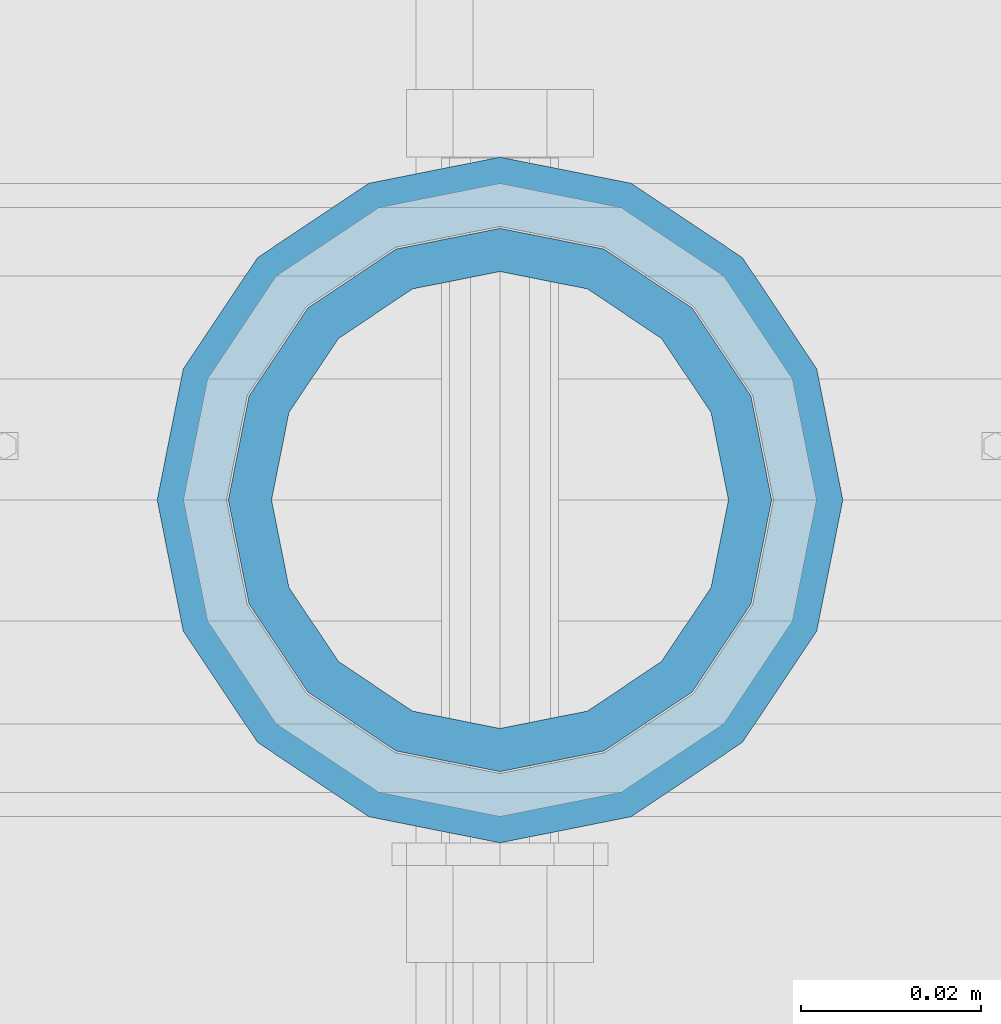
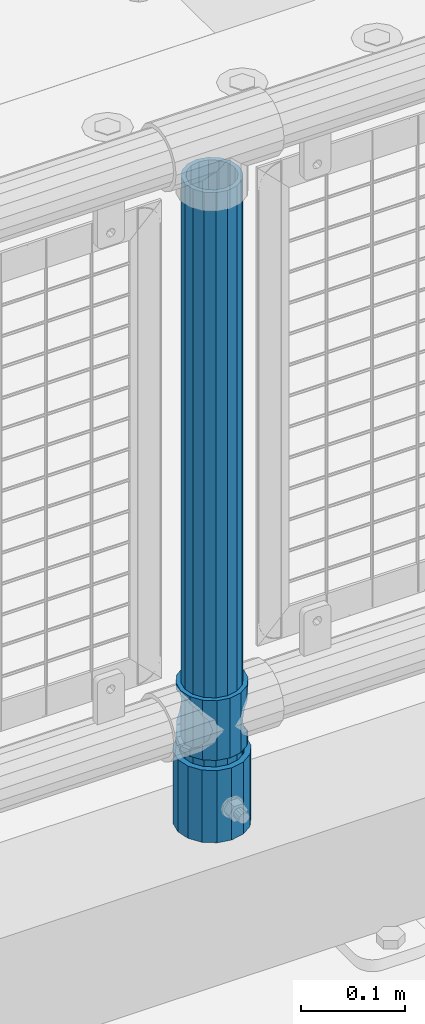
# One storey, part 81 of 270: 3 columns.
"""IFC2X3 building model written with IfcOpenShell, lengths in millimetres."""

from ifc_helpers import new_model, si_unit, frame, origin_with_axes, place, context, subcontext, project, spatial, faceted_brep, material, type_object, element, save


model = new_model("IFC2X3")

# Units and contexts
model_context = context("Model", 3, precision=1e-05, world=origin_with_axes())
body_context = subcontext(model_context, "Body", "Model", "MODEL_VIEW")
ifc_project = project(units=[si_unit("LENGTHUNIT", "METRE", prefix="MILLI"), si_unit("AREAUNIT", "SQUARE_METRE"), si_unit("VOLUMEUNIT", "CUBIC_METRE"), si_unit("MASSUNIT", "GRAM", prefix="KILO"), si_unit("TIMEUNIT", "SECOND"), si_unit("PLANEANGLEUNIT", "RADIAN"), si_unit("SOLIDANGLEUNIT", "STERADIAN"), si_unit("THERMODYNAMICTEMPERATUREUNIT", "DEGREE_CELSIUS"), si_unit("LUMINOUSINTENSITYUNIT", "LUMEN")], contexts=[model_context])

# Site, building, storey
site_placement = place(None, origin_with_axes())
site = spatial("IfcSite", under=ifc_project, at=site_placement, CompositionType="ELEMENT")
building_placement = place(site_placement, origin_with_axes())
building = spatial("IfcBuilding", under=site, at=building_placement, Name="Standard", CompositionType="ELEMENT")
storey_placement = place(building_placement, origin_with_axes())
storey = spatial("IfcBuildingStorey", under=building, at=storey_placement, Name="Undefined", CompositionType="ELEMENT", Elevation=0.0)

# Columns
ifc_material_1 = material()
column_type_1 = type_object("IfcColumnType", PredefinedType="NOTDEFINED")
column_1_placement = place(storey_placement, frame((7153.0, -16335.5, 168.02), z_axis=(-1.0, 0.0, 0.0), x_axis=(0.0, 0.0, 1.0)))
element("IfcColumn", 1, at=column_1_placement, inside=storey, type_object=column_type_1, material=ifc_material_1, context=body_context, shape_type="Brep", body=[
    faceted_brep([(0.0, -25.3500000000004, 0.0), (0.0, -23.4203461491616, 9.70102501045403), (760.0, -23.4203461491616, 9.70102501045403), (760.0, -25.3500000000004, 0.0), (0.0, -17.9251569030785, 17.9251569030785), (760.0, -17.9251569030785, 17.9251569030785), (0.0, -9.70102501045585, 23.4203461491597), (760.0, -9.70102501045585, 23.4203461491597), (0.0, 0.0, 25.3499999999985), (760.0, 0.0, 25.3499999999985), (0.0, 9.70102501045585, 23.4203461491597), (760.0, 9.70102501045585, 23.4203461491597), (0.0, 17.9251569030785, 17.9251569030785), (760.0, 17.9251569030785, 17.9251569030785), (0.0, 23.4203461491616, 9.70102501045403), (760.0, 23.4203461491616, 9.70102501045403), (0.0, 25.3500000000004, 0.0), (760.0, 25.3500000000004, 0.0), (0.0, 23.4203461491616, -9.70102501045403), (760.0, 23.4203461491616, -9.70102501045403), (0.0, 17.9251569030785, -17.9251569030785), (760.0, 17.9251569030785, -17.9251569030785), (0.0, 9.70102501045585, -23.4203461491597), (760.0, 9.70102501045585, -23.4203461491597), (0.0, 0.0, -25.3499999999985), (760.0, 0.0, -25.3499999999985), (0.0, -9.70102501045585, -23.4203461491597), (760.0, -9.70102501045585, -23.4203461491597), (0.0, -17.9251569030785, -17.9251569030785), (760.0, -17.9251569030785, -17.9251569030785), (0.0, -23.4203461491616, -9.70102501045403), (760.0, -23.4203461491616, -9.70102501045403), (0.0, -30.1499999999996, 0.0), (0.0, -27.8549679052157, -11.5379054858058), (760.0, -27.8549679052157, -11.5379054858058), (760.0, -30.1499999999996, 0.0), (0.0, -21.3192694527752, -21.3192694527752), (760.0, -21.3192694527752, -21.3192694527752), (0.0, -11.5379054858076, -27.8549679052157), (760.0, -11.5379054858076, -27.8549679052157), (0.0, 0.0, -30.1500000000015), (760.0, 0.0, -30.1500000000015), (0.0, 11.5379054858076, -27.8549679052157), (760.0, 11.5379054858076, -27.8549679052157), (0.0, 21.3192694527752, -21.3192694527752), (760.0, 21.3192694527752, -21.3192694527752), (0.0, 27.8549679052157, -11.5379054858058), (760.0, 27.8549679052157, -11.5379054858058), (0.0, 30.1499999999996, 0.0), (760.0, 30.1499999999996, 0.0), (0.0, 27.8549679052157, 11.5379054858058), (760.0, 27.8549679052157, 11.5379054858058), (0.0, 21.3192694527752, 21.3192694527752), (760.0, 21.3192694527752, 21.3192694527752), (0.0, 11.5379054858076, 27.8549679052157), (760.0, 11.5379054858076, 27.8549679052157), (0.0, 0.0, 30.1500000000015), (760.0, 0.0, 30.1500000000015), (0.0, -11.5379054858076, 27.8549679052157), (760.0, -11.5379054858076, 27.8549679052157), (0.0, -21.3192694527752, 21.3192694527752), (760.0, -21.3192694527752, 21.3192694527752), (0.0, -27.8549679052157, 11.5379054858058), (760.0, -27.8549679052157, 11.5379054858058)], [[[0, 1, 2, 3]], [[1, 4, 5, 2]], [[4, 6, 7, 5]], [[6, 8, 9, 7]], [[8, 10, 11, 9]], [[10, 12, 13, 11]], [[12, 14, 15, 13]], [[14, 16, 17, 15]], [[16, 18, 19, 17]], [[18, 20, 21, 19]], [[20, 22, 23, 21]], [[22, 24, 25, 23]], [[24, 26, 27, 25]], [[26, 28, 29, 27]], [[28, 30, 31, 29]], [[30, 0, 3, 31]], [[32, 33, 34, 35]], [[33, 36, 37, 34]], [[36, 38, 39, 37]], [[38, 40, 41, 39]], [[40, 42, 43, 41]], [[42, 44, 45, 43]], [[44, 46, 47, 45]], [[46, 48, 49, 47]], [[48, 50, 51, 49]], [[50, 52, 53, 51]], [[52, 54, 55, 53]], [[54, 56, 57, 55]], [[56, 58, 59, 57]], [[58, 60, 61, 59]], [[60, 62, 63, 61]], [[62, 32, 35, 63]], [[37, 39, 41, 43, 45, 47, 49, 51, 53, 55, 57, 59, 61, 63, 35, 34], [5, 7, 9, 11, 13, 15, 17, 19, 21, 23, 25, 27, 29, 31, 3, 2]], [[62, 60, 58, 56, 54, 52, 50, 48, 46, 44, 42, 40, 38, 36, 33, 32], [30, 28, 26, 24, 22, 20, 18, 16, 14, 12, 10, 8, 6, 4, 1, 0]]]),
])
column_type_2 = type_object("IfcColumnType", PredefinedType="NOTDEFINED")
column_2_placement = place(storey_placement, frame((7153.0, -16335.5, 168.02), z_axis=(0.0, 1.0, 0.0), x_axis=(0.0, 0.0, 1.0)))
element("IfcColumn", 2, at=column_2_placement, inside=storey, type_object=column_type_2, material=ifc_material_1, context=body_context, shape_type="Brep", body=[
    faceted_brep([(0.0, -31.75, 0.0), (0.0, -29.3331751572332, 12.1501989775916), (85.0, -29.3331751572332, 12.1501989775916), (85.0, -31.75, 0.0), (0.0, -22.4506403026717, 22.4506403026735), (85.0, -22.4506403026717, 22.4506403026735), (0.0, -12.1501989775934, 29.3331751572332), (85.0, -12.1501989775934, 29.3331751572332), (0.0, 0.0, 31.75), (85.0, 0.0, 31.75), (0.0, 12.1501989775934, 29.3331751572332), (85.0, 12.1501989775934, 29.3331751572332), (0.0, 22.4506403026717, 22.4506403026735), (85.0, 22.4506403026717, 22.4506403026735), (0.0, 29.3331751572332, 12.1501989775916), (85.0, 29.3331751572332, 12.1501989775916), (0.0, 31.75, 0.0), (85.0, 31.75, 0.0), (0.0, 29.3331751572332, -12.1501989775916), (85.0, 29.3331751572332, -12.1501989775916), (0.0, 22.4506403026717, -22.4506403026735), (85.0, 22.4506403026717, -22.4506403026735), (0.0, 12.1501989775934, -29.3331751572332), (85.0, 12.1501989775934, -29.3331751572332), (0.0, 0.0, -31.75), (85.0, 0.0, -31.75), (0.0, -12.1501989775934, -29.3331751572332), (85.0, -12.1501989775934, -29.3331751572332), (0.0, -22.4506403026717, -22.4506403026735), (85.0, -22.4506403026717, -22.4506403026735), (0.0, -29.3331751572332, -12.1501989775916), (85.0, -29.3331751572332, -12.1501989775916), (0.0, -38.0499999999993, 0.0), (0.0, -35.1536162120537, -14.561104601491), (85.0, -35.1536162120537, -14.561104601491), (85.0, -38.0499999999993, 0.0), (0.0, -26.9054130241493, -26.9054130241475), (85.0, -26.9054130241493, -26.9054130241475), (0.0, -14.5611046014928, -35.1536162120537), (85.0, -14.5611046014928, -35.1536162120537), (0.0, 0.0, -38.0499999999993), (85.0, 0.0, -38.0499999999993), (0.0, 14.5611046014928, -35.1536162120537), (85.0, 14.5611046014928, -35.1536162120537), (0.0, 26.9054130241493, -26.9054130241475), (85.0, 26.9054130241493, -26.9054130241475), (0.0, 35.1536162120537, -14.561104601491), (85.0, 35.1536162120537, -14.561104601491), (0.0, 38.0499999999993, 0.0), (85.0, 38.0499999999993, 0.0), (0.0, 35.1536162120537, 14.561104601491), (85.0, 35.1536162120537, 14.561104601491), (0.0, 26.9054130241493, 26.9054130241475), (85.0, 26.9054130241493, 26.9054130241475), (0.0, 14.5611046014928, 35.1536162120537), (85.0, 14.5611046014928, 35.1536162120537), (0.0, 0.0, 38.0499999999993), (85.0, 0.0, 38.0499999999993), (0.0, -14.5611046014928, 35.1536162120537), (85.0, -14.5611046014928, 35.1536162120537), (0.0, -26.9054130241493, 26.9054130241475), (85.0, -26.9054130241493, 26.9054130241475), (0.0, -35.1536162120537, 14.561104601491), (85.0, -35.1536162120537, 14.561104601491)], [[[0, 1, 2, 3]], [[1, 4, 5, 2]], [[4, 6, 7, 5]], [[6, 8, 9, 7]], [[8, 10, 11, 9]], [[10, 12, 13, 11]], [[12, 14, 15, 13]], [[14, 16, 17, 15]], [[16, 18, 19, 17]], [[18, 20, 21, 19]], [[20, 22, 23, 21]], [[22, 24, 25, 23]], [[24, 26, 27, 25]], [[26, 28, 29, 27]], [[28, 30, 31, 29]], [[30, 0, 3, 31]], [[32, 33, 34, 35]], [[33, 36, 37, 34]], [[36, 38, 39, 37]], [[38, 40, 41, 39]], [[40, 42, 43, 41]], [[42, 44, 45, 43]], [[44, 46, 47, 45]], [[46, 48, 49, 47]], [[48, 50, 51, 49]], [[50, 52, 53, 51]], [[52, 54, 55, 53]], [[54, 56, 57, 55]], [[56, 58, 59, 57]], [[58, 60, 61, 59]], [[60, 62, 63, 61]], [[62, 32, 35, 63]], [[37, 39, 41, 43, 45, 47, 49, 51, 53, 55, 57, 59, 61, 63, 35, 34], [5, 7, 9, 11, 13, 15, 17, 19, 21, 23, 25, 27, 29, 31, 3, 2]], [[62, 60, 58, 56, 54, 52, 50, 48, 46, 44, 42, 40, 38, 36, 33, 32], [30, 28, 26, 24, 22, 20, 18, 16, 14, 12, 10, 8, 6, 4, 1, 0]]]),
])
ifc_material_2 = material(Name="Misc_Undefined")
column_type_3 = type_object("IfcColumnType", PredefinedType="NOTDEFINED")
column_3_placement = place(storey_placement, frame((7153.0, -16335.5, 263.02), z_axis=(-1.0, 0.0, 0.0), x_axis=(0.0, 0.0, 1.0)))
element("IfcColumn", 3, at=column_3_placement, inside=storey, type_object=column_type_3, material=ifc_material_2, context=body_context, shape_type="Brep", body=[
    faceted_brep([(63.1897438117183, 11.6144421722802, -32.8397438117208), (63.1897438117183, 11.6144421722802, -28.0397438117179), (56.6106908090125, 21.4606908090118, -21.46069080901), (56.6106908090125, 21.4606908090118, -27.1226768591005), (61.9623795176767, 13.4513226476338, -32.4743655677703), (46.7644421722812, 28.0397438117179, -11.614442172282), (46.7644421722812, 28.0397438117179, -20.0882031229812), (51.5310424080071, 24.8548033587067, -24.8548033587067), (35.1500000000015, 30.35, 0.0), (35.1500000000008, 30.3500000000004, -16.6306603983612), (23.5355578277203, 28.0397438117179, -11.614442172282), (23.5355578277203, 28.0397438117179, -20.0882031229812), (18.7689575919954, 24.8548033587067, -24.8548033587067), (13.689309190989, 21.4606908090118, -21.46069080901), (13.689309190989, 21.4606908090118, -27.1226768591005), (8.33762048232484, 13.4513226476338, -32.4743655677703), (7.11025618828324, 11.6144421722802, -28.0397438117179), (7.11025618828324, 11.6144421722802, -32.8397438117208), (4.80000000000075, 0.0, -30.3499999999985), (4.80000000000075, 0.0, -35.1500000000015), (7.11025618828319, -11.6144421722802, -28.0397438117179), (7.11025618828319, -11.6144421722802, -32.8397438117172), (13.689309190989, -21.4606908090118, -21.46069080901), (13.689309190989, -21.4606908090118, -27.1226768591041), (8.33762048232484, -13.4513226476338, -32.4743655677703), (23.5355578277203, -28.0397438117179, -11.614442172282), (23.5355578277203, -28.0397438117179, -20.0882031229885), (18.7689575919954, -24.8548033587067, -24.8548033587067), (35.1500000000015, -30.35, 0.0), (35.1500000000008, -30.3500000000004, -16.6306603983721), (46.7644421722812, -28.0397438117179, -11.614442172282), (46.7644421722812, -28.0397438117179, -20.0882031229885), (51.5310424080071, -24.8548033587067, -24.8548033587067), (56.6106908090125, -21.4606908090118, -21.46069080901), (56.6106908090125, -21.4606908090118, -27.1226768591041), (61.9623795176767, -13.4513226476338, -32.4743655677703), (63.1897438117183, -11.6144421722802, -28.0397438117179), (63.1897438117183, -11.6144421722802, -32.8397438117172), (65.5000000000008, 0.0, -30.3499999999985), (65.5000000000008, 0.0, -35.1500000000015), (0.0, -28.0397438117179, -11.614442172282), (0.0, -30.3500000000004, 0.0), (0.0, -21.4606908090118, -21.46069080901), (0.0, -11.6144421722802, -28.0397438117179), (0.0, 0.0, -30.3499999999985), (0.0, 11.6144421722802, -28.0397438117179), (0.0, 21.4606908090118, -21.46069080901), (0.0, 28.0397438117179, -11.614442172282), (0.0, 30.3500000000004, 0.0), (0.0, 28.0397438117179, 11.614442172282), (23.5355578277192, 28.0397438117179, 11.614442172282), (0.0, 21.4606908090118, 21.46069080901), (13.6893091909879, 21.4606908090118, 21.46069080901), (0.0, 11.6144421722802, 28.0397438117179), (7.11025618828211, 11.6144421722802, 28.0397438117179), (0.0, 0.0, 30.3499999999985), (4.79999999999961, 0.0, 30.3499999999985), (0.0, -11.6144421722802, 28.0397438117179), (7.11025618828205, -11.6144421722802, 28.0397438117179), (0.0, -21.4606908090118, 21.46069080901), (13.6893091909879, -21.4606908090118, 21.46069080901), (0.0, -28.0397438117179, 11.614442172282), (23.5355578277191, -28.0397438117179, 11.614442172282), (0.0, -32.4743655677721, 13.4513226476338), (0.0, -35.1499999999996, 0.0), (70.2999999999993, -35.1499999999996, 0.0), (70.2999999999993, -32.4743655677721, 13.4513226476338), (0.0, 13.4513226476338, -32.4743655677703), (0.0, 24.8548033587067, -24.8548033587067), (0.0, 0.0, -35.1499999999996), (0.0, -13.4513226476338, -32.4743655677703), (0.0, -24.8548033587067, -24.8548033587067), (0.0, -24.8548033587067, 24.8548033587067), (0.0, -13.4513226476338, 32.4743655677703), (0.0, 0.0, 35.1499999999996), (0.0, 13.4513226476338, 32.4743655677703), (0.0, 24.8548033587067, 24.8548033587067), (0.0, 32.4743655677721, 13.4513226476338), (0.0, 35.1499999999996, 0.0), (0.0, 32.4743655677721, -13.4513226476338), (0.0, -32.4743655677721, -13.4513226476338), (70.2999999999993, 32.4743655677721, 13.4513226476338), (70.2999999999993, 35.1499999999996, 0.0), (70.2999999999993, 32.4743655677721, -13.4513226476338), (70.2999999999993, 24.8548033587067, -24.8548033587067), (70.2999999999993, 13.4513226476338, -32.4743655677703), (70.2999999999993, 0.0, -35.1500000000015), (70.2999999999993, -13.4513226476338, -32.4743655677703), (70.2999999999993, -24.8548033587067, -24.8548033587067), (70.2999999999993, -32.4743655677721, -13.4513226476338), (70.2999999999993, 28.0397438117179, 11.614442172282), (70.2999999999993, 21.4606908090118, 21.46069080901), (56.6106908090114, 21.4606908090118, 21.46069080901), (46.7644421722801, 28.0397438117179, 11.614442172282), (70.2999999999993, 11.6144421722802, 28.0397438117179), (63.1897438117172, 11.6144421722802, 28.0397438117179), (70.2999999999993, 0.0, 30.3499999999985), (65.4999999999997, 0.0, 30.3499999999985), (70.2999999999993, -11.6144421722802, 28.0397438117179), (63.1897438117172, -11.6144421722802, 28.0397438117179), (70.2999999999993, -21.4606908090118, 21.46069080901), (56.6106908090114, -21.4606908090118, 21.46069080901), (70.2999999999993, -28.0397438117179, 11.614442172282), (46.7644421722801, -28.0397438117179, 11.614442172282), (70.2999999999993, -11.6144421722802, -28.0397438117179), (70.2999999999993, 0.0, -30.3499999999985), (70.2999999999993, -21.4606908090118, -21.46069080901), (70.2999999999993, -28.0397438117179, -11.614442172282), (70.2999999999993, -30.3500000000004, 0.0), (70.2999999999993, 24.8548033587067, 24.8548033587067), (70.2999999999993, 13.4513226476338, 32.4743655677703), (70.2999999999993, 0.0, 35.1500000000015), (70.2999999999993, -13.4513226476338, 32.4743655677703), (70.2999999999993, -24.8548033587067, 24.8548033587067), (70.2999999999993, 30.3500000000004, 0.0), (70.2999999999993, 28.0397438117179, -11.614442172282), (70.2999999999993, 21.4606908090118, -21.46069080901), (70.2999999999993, 11.6144421722802, -28.0397438117179), (61.9623795176767, 13.4513226476338, 32.4743655677703), (51.5310424080039, 24.8548033587067, 24.8548033587067), (56.6106908090114, 21.4606908090118, 27.1226768591041), (65.4999999999997, 0.0, 35.1500000000015), (63.1897438117172, 11.6144421722802, 32.8397438117172), (63.1897438117172, -11.6144421722802, 32.8397438117172), (61.9623795176767, -13.4513226476338, 32.4743655677703), (56.6106908090114, -21.4606908090118, 27.1226768591077), (51.5310424080071, -24.8548033587067, 24.8548033587067), (18.7689575919954, -24.8548033587067, 24.8548033587067), (46.7644421722801, -28.0397438117179, 20.0882031229849), (35.1499999999996, -30.3500000000004, 16.6306603983649), (23.5355578277191, -28.0397438117179, 20.0882031229849), (8.33762048232262, -13.4513226476338, 32.4743655677703), (13.6893091909879, -21.4606908090118, 27.1226768591077), (4.79999999999961, 0.0, 35.1500000000015), (7.11025618828205, -11.6144421722802, 32.8397438117172), (7.11025618828211, 11.6144421722802, 32.8397438117172), (8.33762048232262, 13.4513226476338, 32.4743655677703), (13.6893091909879, 21.4606908090118, 27.1226768591041), (18.7689575919954, 24.8548033587067, 24.8548033587067), (23.5355578277192, 28.0397438117179, 20.0882031229885), (35.1499999999996, 30.3500000000004, 16.6306603983685), (46.7644421722801, 28.0397438117179, 20.0882031229885)], [[[0, 1, 2, 3, 4]], [[3, 2, 5, 6, 7]], [[6, 5, 8, 9]], [[9, 8, 10, 11]], [[12, 11, 10, 13, 14]], [[15, 14, 13, 16, 17]], [[17, 16, 18, 19]], [[19, 18, 20, 21]], [[21, 20, 22, 23, 24]], [[23, 22, 25, 26, 27]], [[26, 25, 28, 29]], [[29, 28, 30, 31]], [[32, 31, 30, 33, 34]], [[35, 34, 33, 36, 37]], [[37, 36, 38, 39]], [[39, 38, 1, 0]], [[40, 41, 28, 25]], [[42, 40, 25, 22]], [[43, 42, 22, 20]], [[44, 43, 20, 18]], [[45, 44, 18, 16]], [[46, 45, 16, 13]], [[47, 46, 13, 10]], [[48, 47, 10, 8]], [[49, 48, 8, 50]], [[51, 49, 50, 52]], [[53, 51, 52, 54]], [[55, 53, 54, 56]], [[57, 55, 56, 58]], [[59, 57, 58, 60]], [[61, 59, 60, 62]], [[41, 61, 62, 28]], [[63, 64, 65, 66]], [[67, 68, 12, 14, 15]], [[69, 67, 15, 17, 19]], [[24, 70, 69, 19, 21]], [[27, 71, 70, 24, 23]], [[63, 72, 73, 74, 75, 76, 77, 78, 79, 68, 67, 69, 70, 71, 80, 64], [40, 42, 43, 44, 45, 46, 47, 48, 49, 51, 53, 55, 57, 59, 61, 41]], [[78, 77, 81, 82]], [[79, 78, 82, 83]], [[68, 79, 83, 84, 7, 6, 9, 11, 12]], [[7, 84, 85, 4, 3]], [[4, 85, 86, 39, 0]], [[87, 88, 32, 34, 35]], [[86, 87, 35, 37, 39]], [[29, 31, 32, 88, 89, 80, 71, 27, 26]], [[64, 80, 89, 65]], [[90, 91, 92, 93]], [[91, 94, 95, 92]], [[94, 96, 97, 95]], [[96, 98, 99, 97]], [[98, 100, 101, 99]], [[100, 102, 103, 101]], [[104, 105, 38, 36]], [[106, 104, 36, 33]], [[107, 106, 33, 30]], [[108, 107, 30, 28]], [[102, 108, 28, 103]], [[88, 87, 86, 85, 84, 83, 82, 81, 109, 110, 111, 112, 113, 66, 65, 89], [100, 98, 96, 94, 91, 90, 114, 115, 116, 117, 105, 104, 106, 107, 108, 102]], [[118, 110, 109, 119, 120]], [[121, 111, 110, 118, 122]], [[112, 111, 121, 123, 124]], [[113, 112, 124, 125, 126]], [[127, 72, 63, 66, 113, 126, 128, 129, 130]], [[131, 73, 72, 127, 132]], [[133, 74, 73, 131, 134]], [[75, 74, 133, 135, 136]], [[76, 75, 136, 137, 138]], [[119, 109, 81, 77, 76, 138, 139, 140, 141]], [[92, 120, 119, 141, 93]], [[95, 122, 118, 120, 92]], [[97, 121, 122, 95]], [[99, 123, 121, 97]], [[101, 125, 124, 123, 99]], [[103, 128, 126, 125, 101]], [[28, 129, 128, 103]], [[62, 130, 129, 28]], [[60, 132, 127, 130, 62]], [[58, 134, 131, 132, 60]], [[56, 133, 134, 58]], [[54, 135, 133, 56]], [[52, 137, 136, 135, 54]], [[50, 139, 138, 137, 52]], [[8, 140, 139, 50]], [[93, 141, 140, 8]], [[114, 90, 93, 8]], [[115, 114, 8, 5]], [[116, 115, 5, 2]], [[117, 116, 2, 1]], [[105, 117, 1, 38]]]),
])

save(model, "model.ifc")
